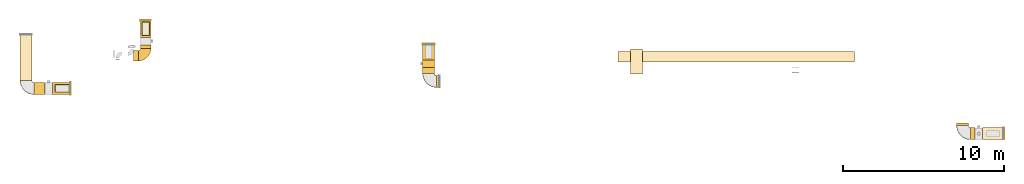
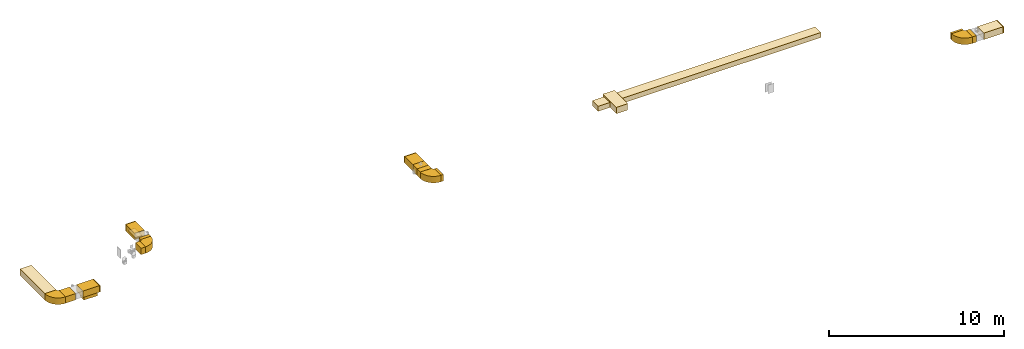
# One storey, part 1 of 8: 27 coverings.
"""IFC2X3 building model written with IfcOpenShell, lengths in millimetres."""

from ifc_helpers import new_model, entity, si_unit, converted_unit, derived_unit, direction, frame, frame_2d, origin, origin_2d_with_axis, place, context, subcontext, project, spatial, polyline, circle_curve, parameter, trimmed, segment, composite_curve, rectangle, outline, extrude, element, save


model = new_model("IFC2X3")

# Units and contexts
model_context = context("Model", 3, precision=0.01, world=origin(), true_north=direction((6.12303176911189e-17, 1.0)))
body_context = subcontext(model_context, "Body", "Model", "MODEL_VIEW")
ifc_project = project(units=[si_unit("LENGTHUNIT", "METRE", prefix="MILLI"), si_unit("AREAUNIT", "SQUARE_METRE"), si_unit("VOLUMEUNIT", "CUBIC_METRE"), converted_unit("PLANEANGLEUNIT", "DEGREE", entity("IfcRatioMeasure", 0.0174532925199433), si_unit("PLANEANGLEUNIT", "RADIAN"), dimensions=[0, 0, 0, 0, 0, 0, 0]), si_unit("MASSUNIT", "GRAM", prefix="KILO"), derived_unit("MASSDENSITYUNIT", [(si_unit("MASSUNIT", "GRAM", prefix="KILO"), 1), (si_unit("LENGTHUNIT", "METRE"), -3)]), derived_unit("MOMENTOFINERTIAUNIT", [(si_unit("LENGTHUNIT", "METRE"), 4)]), si_unit("TIMEUNIT", "SECOND"), si_unit("FREQUENCYUNIT", "HERTZ"), si_unit("THERMODYNAMICTEMPERATUREUNIT", "DEGREE_CELSIUS"), derived_unit("THERMALTRANSMITTANCEUNIT", [(si_unit("MASSUNIT", "GRAM", prefix="KILO"), 1), (si_unit("THERMODYNAMICTEMPERATUREUNIT", "KELVIN"), -1), (si_unit("TIMEUNIT", "SECOND"), -3)]), derived_unit("VOLUMETRICFLOWRATEUNIT", [(si_unit("LENGTHUNIT", "METRE"), 3), (si_unit("TIMEUNIT", "SECOND"), -1)]), derived_unit("MASSFLOWRATEUNIT", [(si_unit("MASSUNIT", "GRAM", prefix="KILO"), 1), (si_unit("TIMEUNIT", "SECOND"), -1)]), derived_unit("ROTATIONALFREQUENCYUNIT", [(si_unit("TIMEUNIT", "SECOND"), -1)]), si_unit("ELECTRICCURRENTUNIT", "AMPERE"), si_unit("ELECTRICVOLTAGEUNIT", "VOLT"), si_unit("POWERUNIT", "WATT"), si_unit("FORCEUNIT", "NEWTON", prefix="KILO"), si_unit("ILLUMINANCEUNIT", "LUX"), si_unit("LUMINOUSFLUXUNIT", "LUMEN"), si_unit("LUMINOUSINTENSITYUNIT", "CANDELA"), derived_unit("USERDEFINED", [(si_unit("MASSUNIT", "GRAM", prefix="KILO"), -1), (si_unit("LENGTHUNIT", "METRE"), -2), (si_unit("TIMEUNIT", "SECOND"), 3), (si_unit("LUMINOUSFLUXUNIT", "LUMEN"), 1)]), derived_unit("LINEARVELOCITYUNIT", [(si_unit("LENGTHUNIT", "METRE"), 1), (si_unit("TIMEUNIT", "SECOND"), -1)]), si_unit("PRESSUREUNIT", "PASCAL"), derived_unit("USERDEFINED", [(si_unit("LENGTHUNIT", "METRE"), -2), (si_unit("MASSUNIT", "GRAM", prefix="KILO"), 1), (si_unit("TIMEUNIT", "SECOND"), -2)]), derived_unit("LINEARFORCEUNIT", [(si_unit("MASSUNIT", "GRAM", prefix="KILO"), 1), (si_unit("LENGTHUNIT", "METRE"), 1), (si_unit("TIMEUNIT", "SECOND"), -2), (si_unit("LENGTHUNIT", "METRE"), -1)]), derived_unit("PLANARFORCEUNIT", [(si_unit("MASSUNIT", "GRAM", prefix="KILO"), 1), (si_unit("LENGTHUNIT", "METRE"), 1), (si_unit("TIMEUNIT", "SECOND"), -2), (si_unit("LENGTHUNIT", "METRE"), -2)])], contexts=[model_context])

# Site, building, storey
site_placement = place(None, origin())
site = spatial("IfcSite", under=ifc_project, at=site_placement, CompositionType="ELEMENT")
building_placement = place(site_placement, origin())
building = spatial("IfcBuilding", under=site, at=building_placement, CompositionType="ELEMENT")
storey_placement = place(building_placement, frame((0.0, 0.0, 4200.0)))
storey = spatial("IfcBuildingStorey", under=building, at=storey_placement, CompositionType="ELEMENT", Elevation=4200.0)

# Coverings
covering_1_placement = place(storey_placement, frame((42939.85, 14305.07, 2475.0)))
element("IfcCovering", 1, at=covering_1_placement, inside=storey, PredefinedType="INSULATION", context=body_context, shape_type="SweptSolid", body=[
    extrude(rectangle(XDim=13206.0535856904, YDim=650.0, at=origin_2d_with_axis()), frame((6603.03, 325.0, 0.0), z_axis=(0.0, 0.0, 1.0), x_axis=(-1.0, 0.0, 0.0)), (0.0, 0.0, 1.0), 350.000000000001),
])
covering_2_placement = place(storey_placement, frame((41411.79, 14305.07, 2475.0)))
element("IfcCovering", 2, at=covering_2_placement, inside=storey, PredefinedType="INSULATION", context=body_context, shape_type="SweptSolid", body=[
    extrude(rectangle(XDim=788.053179273669, YDim=650.0, at=origin_2d_with_axis()), frame((394.03, 325.0, 0.0)), (0.0, 0.0, 1.0), 350.000000000001),
])
covering_3_placement = place(storey_placement, frame((42194.85, 13563.14, 2475.0)))
element("IfcCovering", 3, at=covering_3_placement, inside=storey, PredefinedType="INSULATION", context=body_context, shape_type="SweptSolid", body=[
    extrude(rectangle(XDim=1542.05774942284, YDim=750.000000000003, at=origin_2d_with_axis()), frame((375.0, 771.03, 0.0), z_axis=(0.0, 0.0, 1.0), x_axis=(0.0, 1.0, 0.0)), (0.0, 0.0, 1.0), 449.999999999999),
])
covering_4_placement = place(storey_placement, frame((29245.05, 14439.7, 2475.0)))
element("IfcCovering", 4, at=covering_4_placement, inside=storey, PredefinedType="INSULATION", context=body_context, shape_type="SweptSolid", body=[
    extrude(rectangle(XDim=937.535158670706, YDim=750.000000000003, at=origin_2d_with_axis()), frame((375.0, 468.77, 0.0), z_axis=(0.0, 0.0, 1.0), x_axis=(0.0, -1.0, 0.0)), (0.0, 0.0, 1.0), 449.999999999999),
])
covering_5_placement = place(storey_placement, frame((29245.05, 15377.24, 2475.0)))
element("IfcCovering", 5, at=covering_5_placement, inside=storey, PredefinedType="INSULATION", context=body_context, shape_type="SweptSolid", body=[
    extrude(rectangle(XDim=50.0000000000016, YDim=749.999999999998, at=origin_2d_with_axis()), frame((375.0, 25.0, 0.0), z_axis=(0.0, 0.0, 1.0), x_axis=(0.0, -1.0, 0.0)), (0.0, 0.0, 1.0), 449.999999999999),
])
covering_6_placement = place(storey_placement, frame((29245.05, 13587.72, 2475.0)))
element("IfcCovering", 6, at=covering_6_placement, inside=storey, PredefinedType="INSULATION", context=body_context, shape_type="SweptSolid", body=[
    extrude(rectangle(XDim=371.982987517842, YDim=750.000000000003, at=origin_2d_with_axis()), frame((375.0, 185.99, 0.0), z_axis=(0.0, 0.0, 1.0), x_axis=(0.0, 1.0, 0.0)), (0.0, 0.0, 1.0), 449.999999999999),
])
covering_7_placement = place(storey_placement, frame((30120.05, 12712.72, 2475.0)))
element("IfcCovering", 7, at=covering_7_placement, inside=storey, PredefinedType="INSULATION", context=body_context, shape_type="SweptSolid", body=[
    extrude(rectangle(XDim=154.950539610895, YDim=749.999999999998, at=origin_2d_with_axis()), frame((77.48, 375.0, 0.0), z_axis=(0.0, 0.0, 1.0), x_axis=(-1.0, 0.0, 0.0)), (0.0, 0.0, 1.0), 450.000000000001),
])
covering_8_placement = place(storey_placement, frame((29245.05, 13959.7, 2475.0)))
element("IfcCovering", 8, at=covering_8_placement, inside=storey, PredefinedType="INSULATION", context=body_context, shape_type="SweptSolid", body=[
    extrude(rectangle(XDim=480.000000000001, YDim=750.000000000003, at=origin_2d_with_axis()), frame((375.0, 240.0, 0.0), z_axis=(0.0, 0.0, 1.0), x_axis=(0.0, 1.0, 0.0)), (0.0, 0.0, 1.0), 449.999999999999),
])
covering_9_placement = place(storey_placement, frame((64110.0, 9460.42, 2475.0)))
element("IfcCovering", 9, at=covering_9_placement, inside=storey, PredefinedType="INSULATION", context=body_context, shape_type="SweptSolid", body=[
    extrude(rectangle(XDim=1288.00000000007, YDim=750.0, at=origin_2d_with_axis()), frame((644.0, 375.0, 0.0)), (0.0, 0.0, 1.0), 449.999999999999),
])
covering_10_placement = place(storey_placement, frame((65398.0, 9460.42, 2475.0)))
element("IfcCovering", 10, at=covering_10_placement, inside=storey, PredefinedType="INSULATION", context=body_context, shape_type="SweptSolid", body=[
    extrude(rectangle(XDim=50.000000000006, YDim=750.0, at=origin_2d_with_axis()), frame((25.0, 375.0, 0.0), z_axis=(0.0, 0.0, 1.0), x_axis=(-1.0, 0.0, 0.0)), (0.0, 0.0, 1.0), 449.999999999999),
])
covering_11_placement = place(storey_placement, frame((63370.68, 9460.39, 2475.0)))
element("IfcCovering", 11, at=covering_11_placement, inside=storey, PredefinedType="INSULATION", context=body_context, shape_type="SweptSolid", body=[
    extrude(rectangle(XDim=259.316891872014, YDim=750.0, at=origin_2d_with_axis()), frame((129.66, 375.0, 0.0), z_axis=(0.0, 0.0, 1.0), x_axis=(-1.0, 0.0, 0.0)), (0.0, 0.0, 1.0), 449.999999999999),
])
covering_12_placement = place(storey_placement, frame((62495.68, 10335.39, 2475.0)))
element("IfcCovering", 12, at=covering_12_placement, inside=storey, PredefinedType="INSULATION", context=body_context, shape_type="SweptSolid", body=[
    extrude(rectangle(XDim=153.114137751644, YDim=750.000000000003, at=origin_2d_with_axis()), frame((375.0, 76.56, 0.0), z_axis=(0.0, 0.0, 1.0), x_axis=(0.0, 1.0, 0.0)), (0.0, 0.0, 1.0), 449.999999999999),
])
covering_13_placement = place(storey_placement, frame((4174.45, 13150.47, 3025.0)))
element("IfcCovering", 13, at=covering_13_placement, inside=storey, PredefinedType="INSULATION", context=body_context, shape_type="SweptSolid", body=[
    extrude(rectangle(XDim=2839.50726337812, YDim=750.0, at=origin_2d_with_axis()), frame((375.0, 1419.75, 0.0), z_axis=(0.0, 0.0, 1.0), x_axis=(0.0, 1.0, 0.0)), (0.0, 0.0, 1.0), 449.999999999999),
])
covering_14_placement = place(storey_placement, frame((6194.94, 12275.47, 3025.0)))
element("IfcCovering", 14, at=covering_14_placement, inside=storey, PredefinedType="INSULATION", context=body_context, shape_type="SweptSolid", body=[
    extrude(rectangle(XDim=1094.22665279493, YDim=749.999999999998, at=origin_2d_with_axis()), frame((547.11, 375.0, 0.0), z_axis=(0.0, 0.0, 1.0), x_axis=(-1.0, 0.0, 0.0)), (0.0, 0.0, 1.0), 449.999999999999),
])
covering_15_placement = place(storey_placement, frame((5049.45, 12275.47, 3025.0)))
element("IfcCovering", 15, at=covering_15_placement, inside=storey, PredefinedType="INSULATION", context=body_context, shape_type="SweptSolid", body=[
    extrude(rectangle(XDim=665.48850074056, YDim=749.999999999998, at=origin_2d_with_axis()), frame((332.74, 375.0, 0.0), z_axis=(0.0, 0.0, 1.0), x_axis=(-1.0, 0.0, 0.0)), (0.0, 0.0, 1.0), 449.999999999999),
])
covering_16_placement = place(storey_placement, frame((7289.17, 12275.47, 3025.0)))
element("IfcCovering", 16, at=covering_16_placement, inside=storey, PredefinedType="INSULATION", context=body_context, shape_type="SweptSolid", body=[
    extrude(rectangle(XDim=50.0000000000016, YDim=750.000000000001, at=origin_2d_with_axis()), frame((25.0, 375.0, 0.0), z_axis=(0.0, 0.0, 1.0), x_axis=(-1.0, 0.0, 0.0)), (0.0, 0.0, 1.0), 449.999999999999),
])
covering_17_placement = place(storey_placement, frame((6349.71, 12419.66, 2700.0)))
element("IfcCovering", 17, at=covering_17_placement, inside=storey, PredefinedType="INSULATION", context=body_context, shape_type="SweptSolid", body=[
    extrude(rectangle(XDim=875.0, YDim=475.0, at=origin_2d_with_axis()), frame((437.5, 237.5, 0.0)), (0.0, 0.0, 1.0), 329.999999999994),
])
covering_18_placement = place(storey_placement, frame((11246.02, 14369.08, 2975.0)))
element("IfcCovering", 18, at=covering_18_placement, inside=storey, PredefinedType="INSULATION", context=body_context, shape_type="SweptSolid", body=[
    extrude(rectangle(XDim=304.195841947545, YDim=650.0, at=origin_2d_with_axis()), frame((152.1, 325.0, 0.0), z_axis=(0.0, 0.0, 1.0), x_axis=(-1.0, 0.0, 0.0)), (0.0, 0.0, 1.0), 449.999999999999),
])
covering_19_placement = place(storey_placement, frame((11783.22, 15944.97, 2900.0)))
element("IfcCovering", 19, at=covering_19_placement, inside=storey, PredefinedType="INSULATION", context=body_context, shape_type="SweptSolid", body=[
    extrude(rectangle(XDim=850.000000000002, YDim=450.000000000002, at=origin_2d_with_axis()), frame((225.0, 425.0, 0.0), z_axis=(0.0, 0.0, 1.0), x_axis=(0.0, -1.0, 0.0)), (0.0, 0.0, 1.0), 80.0000000000002),
])
covering_20_placement = place(storey_placement, frame((11675.22, 15144.08, 2975.0)))
element("IfcCovering", 20, at=covering_20_placement, inside=storey, PredefinedType="INSULATION", context=body_context, shape_type="SweptSolid", body=[
    extrude(rectangle(XDim=216.297032725026, YDim=650.0, at=origin_2d_with_axis()), frame((325.0, 108.15, 0.0), z_axis=(0.0, 0.0, 1.0), x_axis=(0.0, -1.0, 0.0)), (0.0, 0.0, 1.0), 449.999999999999),
])
covering_21_placement = place(storey_placement, frame((11675.22, 15840.38, 2975.0)))
element("IfcCovering", 21, at=covering_21_placement, inside=storey, PredefinedType="INSULATION", context=body_context, shape_type="SweptSolid", body=[
    extrude(rectangle(XDim=1025.0, YDim=650.0, at=origin_2d_with_axis()), frame((325.0, 512.5, 0.0), z_axis=(0.0, 0.0, 1.0), x_axis=(0.0, 1.0, 0.0)), (0.0, 0.0, 1.0), 449.999999999999),
])
covering_22_placement = place(storey_placement, frame((11675.22, 16865.38, 2975.0)))
element("IfcCovering", 22, at=covering_22_placement, inside=storey, PredefinedType="INSULATION", context=body_context, shape_type="SweptSolid", body=[
    extrude(rectangle(XDim=50.0000000000016, YDim=650.0, at=origin_2d_with_axis()), frame((325.0, 25.0, 0.0), z_axis=(0.0, 0.0, 1.0), x_axis=(0.0, -1.0, 0.0)), (0.0, 0.0, 1.0), 449.999999999999),
])
covering_23_placement = place(storey_placement, frame((11783.22, 15944.97, 2980.0)))
element("IfcCovering", 23, at=covering_23_placement, inside=storey, PredefinedType="INSULATION", context=body_context, shape_type="SweptSolid", body=[
    extrude(rectangle(XDim=850.000000000002, YDim=450.000000000002, at=origin_2d_with_axis()), frame((225.0, 425.0, 0.0), z_axis=(0.0, 0.0, 1.0), x_axis=(0.0, -1.0, 0.0)), (0.0, 0.0, 1.0), 51.0960000000016),
])
for number, where in (
    (24, (29243.46, 12711.13, 2475.0)),
    (25, (62494.09, 9458.79, 2475.0)),
    (26, (4172.86, 12273.87, 3025.0)),
):
    element("IfcCovering", number, at=place(storey_placement, frame(where)), inside=storey, PredefinedType="INSULATION", context=body_context, shape_type="SweptSolid", body=[
        extrude(outline(composite_curve([segment(polyline([(-250.0, 125.0), (-250.0, -625.0)]), True, "CONTINUOUS"), segment(trimmed(circle_curve(frame_2d((-250.0, 250.0), x_axis=(1.0, 0.0)), 875.0), [parameter(270.0)], [parameter(0.0)], True, "PARAMETER"), True, "CONTINUOUS"), segment(polyline([(625.0, 250.0), (-125.0, 250.0)]), True, "CONTINUOUS"), segment(trimmed(circle_curve(frame_2d((-250.0, 250.0), x_axis=(1.0, 0.0)), 125.0), [parameter(270.0)], [parameter(360.0)], True, "PARAMETER"), False, "CONTINUOUS")], self_intersect=False)), frame((626.6, 626.6, 0.0), z_axis=(0.0, 0.0, -1.0), x_axis=(-1.0, 0.0, 0.0)), (0.0, 0.0, -1.0), 449.999999999999),
    ])
covering_24_placement = place(storey_placement, frame((11548.62, 14367.49, 2975.0)))
element("IfcCovering", 27, at=covering_24_placement, inside=storey, PredefinedType="INSULATION", context=body_context, shape_type="SweptSolid", body=[
    extrude(outline(composite_curve([segment(polyline([(-225.0, 100.0), (-225.0, -550.0)]), True, "CONTINUOUS"), segment(trimmed(circle_curve(frame_2d((-225.0, 225.0), x_axis=(1.0, 0.0)), 775.0), [parameter(270.0)], [parameter(0.0)], True, "PARAMETER"), True, "CONTINUOUS"), segment(polyline([(550.0, 225.0), (-100.0, 225.0)]), True, "CONTINUOUS"), segment(trimmed(circle_curve(frame_2d((-225.0, 225.0), x_axis=(1.0, 0.0)), 125.0), [parameter(270.0)], [parameter(360.0)], True, "PARAMETER"), False, "CONTINUOUS")], self_intersect=False)), frame((226.6, 551.6, 0.0), z_axis=(0.0, 0.0, -1.0), x_axis=(0.0, -1.0, 0.0)), (0.0, 0.0, -1.0), 449.999999999999),
])

save(model, "model.ifc")
